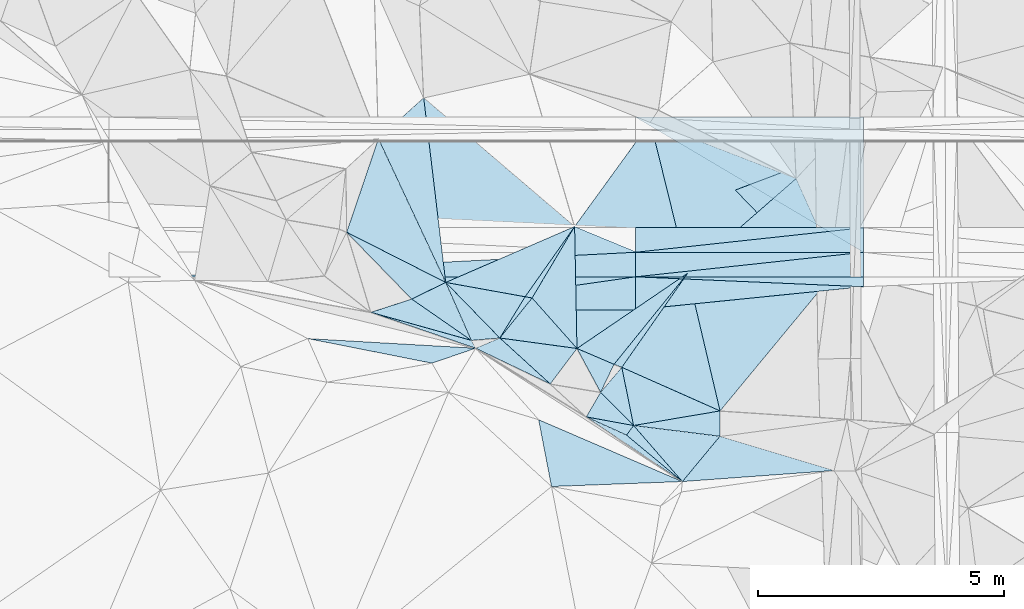
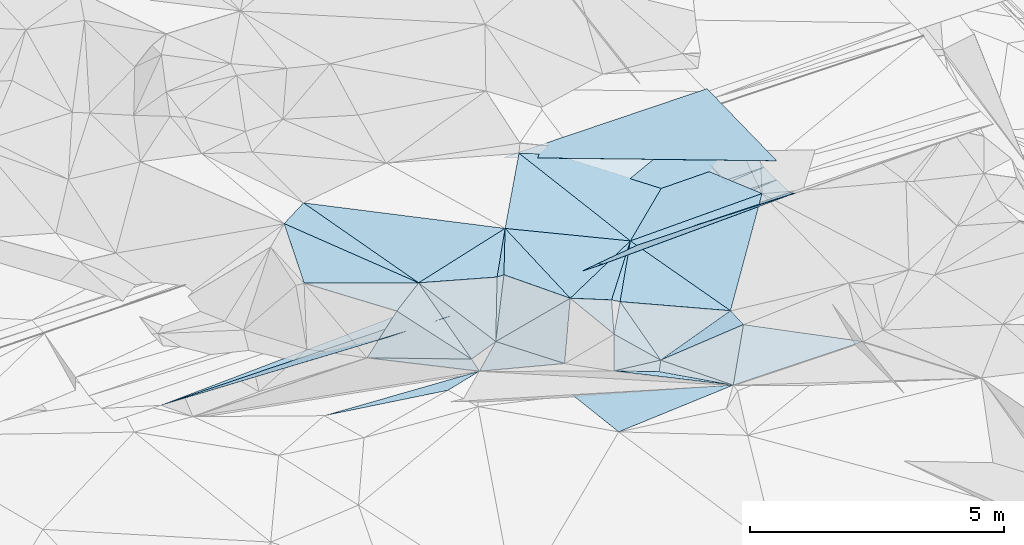
# One storey, part 57 of 275: 47 plates.
"""IFC2X3 building model written with IfcOpenShell, lengths in millimetres."""

from ifc_helpers import new_model, si_unit, frame, origin_with_axes, place, context, subcontext, project, spatial, polyline, outline, extrude, material, type_object, element, save


model = new_model("IFC2X3")

# Units and contexts
model_context = context("Model", 3, precision=1e-05, world=origin_with_axes())
body_context = subcontext(model_context, "Body", "Model", "MODEL_VIEW")
ifc_project = project(units=[si_unit("LENGTHUNIT", "METRE", prefix="MILLI"), si_unit("AREAUNIT", "SQUARE_METRE"), si_unit("VOLUMEUNIT", "CUBIC_METRE"), si_unit("MASSUNIT", "GRAM", prefix="KILO"), si_unit("TIMEUNIT", "SECOND"), si_unit("PLANEANGLEUNIT", "RADIAN"), si_unit("SOLIDANGLEUNIT", "STERADIAN"), si_unit("THERMODYNAMICTEMPERATUREUNIT", "DEGREE_CELSIUS"), si_unit("LUMINOUSINTENSITYUNIT", "LUMEN")], contexts=[model_context])

# Site, building, storey
site_placement = place(None, origin_with_axes())
site = spatial("IfcSite", under=ifc_project, at=site_placement, CompositionType="ELEMENT")
building_placement = place(site_placement, origin_with_axes())
building = spatial("IfcBuilding", under=site, at=building_placement, Name="Undefined", CompositionType="ELEMENT")
storey_placement = place(building_placement, origin_with_axes())
storey = spatial("IfcBuildingStorey", under=building, at=storey_placement, Name="Undefined", CompositionType="ELEMENT", Elevation=0.0)

# Plates
ifc_material = material()
plate_type_1 = type_object("IfcPlateType", PredefinedType="NOTDEFINED")
plate_1_placement = place(storey_placement, frame((-110108.130201798, 60543.2126302947, 49129.6741685446), z_axis=(0.0070360534464846, 0.0249911698384873, -0.999662910876462), x_axis=(0.99997523963564, -5.72709999785377e-05, 0.00703681999743575)))
element("IfcPlate", 1, at=plate_1_placement, inside=storey, type_object=plate_type_1, material=ifc_material, Name="00_PR", context=body_context, shape_type="SweptSolid", body=[
    extrude(outline(polyline([(0.0, 0.0), (4638.88525390625, 2.71393219009042e-09), (4638.4013671875, 2750.85913085938), (0.0, 0.0)])), frame((-8.85201319254618e-08, 2.18876761149539e-07, -0.5000001331573), z_axis=(0.0, 0.0, 1.0), x_axis=(1.0, 0.0, 0.0)), (0.0, 0.0, 1.0), 1.0),
])
plate_type_2 = type_object("IfcPlateType", PredefinedType="NOTDEFINED")
plate_2_placement = place(storey_placement, frame((-111348.333237927, 58316.7714855558, 49209.5070096268), z_axis=(0.118317896493051, -0.117903527485175, -0.985951131434014), x_axis=(-0.511152007933592, -0.858496435201441, 0.0413218529579049)))
element("IfcPlate", 2, at=plate_2_placement, inside=storey, type_object=plate_type_2, material=ifc_material, Name="00", context=body_context, shape_type="SweptSolid", body=[
    extrude(outline(polyline([(0.0, 0.0), (1694.01892089844, -6.30097929388285e-09), (1744.66772460938, 136.508972167969), (0.0, 0.0)])), frame((-8.85201319254618e-08, 2.18876761149539e-07, -0.5000001331573), z_axis=(0.0, 0.0, 1.0), x_axis=(1.0, 0.0, 0.0)), (0.0, 0.0, 1.0), 1.0),
])
plate_type_3 = type_object("IfcPlateType", PredefinedType="NOTDEFINED")
plate_3_placement = place(storey_placement, frame((-111348.462953635, 58316.8629109501, 49209.5060552723), z_axis=(-0.141119786650012, 0.0649496054498312, -0.987859683643262), x_axis=(-0.576000859042115, -0.816949621354208, 0.0285714289450594)))
element("IfcPlate", 3, at=plate_3_placement, inside=storey, type_object=plate_type_3, material=ifc_material, Name="00", context=body_context, shape_type="SweptSolid", body=[
    extrude(outline(polyline([(0.0, 0.0), (1750.0, 6.83940015733242e-10), (2449.71435546875, 1506.28674316406), (0.0, 0.0)])), frame((-8.85201319254618e-08, 2.18876761149539e-07, -0.5000001331573), z_axis=(0.0, 0.0, 1.0), x_axis=(1.0, 0.0, 0.0)), (0.0, 0.0, 1.0), 1.0),
])
plate_type_4 = type_object("IfcPlateType", PredefinedType="NOTDEFINED")
for number, where, z_axis, x_axis, name in (
    (4, (-105469.543799526, 57292.9343954647, 48637.3170069991), (0.00703682011736074, -4.02993598015843e-07, -0.99997524127474), (-0.999975239635043, 5.72709690146696e-05, -0.00703682008264182), "00_PR"),
    (5, (-110108.285337463, 57793.2000715565, 48604.6740063112), (0.00703682011736074, -4.02993598015843e-07, -0.99997524127474), (0.99997523963564, -5.72709999785377e-05, 0.00703681999743575), "00_PR"),
    (6, (-105469.515154169, 57792.9343995453, 48637.3170068708), (0.00703682011736074, -4.02993598015843e-07, -0.99997524127474), (-0.999975239635043, 5.72709690146696e-05, -0.00703682008264182), "00_PR"),
    (7, (-110108.256692113, 58293.2000747863, 48604.6740064954), (0.00703682011736074, -4.02993598015843e-07, -0.99997524127474), (0.99997523963564, -5.72709999785377e-05, 0.00703681999743575), "00_PR"),
):
    element("IfcPlate", number, at=place(storey_placement, frame(where, z_axis=z_axis, x_axis=x_axis)), inside=storey, type_object=plate_type_4, material=ifc_material, Name=name, context=body_context, shape_type="SweptSolid", body=[
        extrude(outline(polyline([(0.0, 0.0), (4638.88525390625, 2.71393219009042e-09), (-1.0997784556821e-05, 500.0), (0.0, 0.0)])), frame((-8.85201319254618e-08, 2.18876761149539e-07, -0.5000001331573), z_axis=(0.0, 0.0, 1.0), x_axis=(1.0, 0.0, 0.0)), (0.0, 0.0, 1.0), 1.0),
    ])
plate_4_placement = place(storey_placement, frame((-110108.284694637, 57793.2000674163, 48604.6740113437), z_axis=(0.00832550512650313, -4.76525014343269e-07, -0.999965342381505), x_axis=(-5.72939716861899e-05, -0.9999999983587, -3.69036567042244e-11)))
element("IfcPlate", 8, at=plate_4_placement, inside=storey, type_object=plate_type_4, material=ifc_material, Name="00_PR", context=body_context, shape_type="SweptSolid", body=[
    extrude(outline(polyline([(0.0, 0.0), (500.0, 8.00355337560177e-10), (499.999267578125, 9668.6904296875), (0.0, 0.0)])), frame((-8.85201319254618e-08, 2.18876761149539e-07, -0.5000001331573), z_axis=(0.0, 0.0, 1.0), x_axis=(1.0, 0.0, 0.0)), (0.0, 0.0, 1.0), 1.0),
])
plate_type_5 = type_object("IfcPlateType", PredefinedType="NOTDEFINED")
plate_5_placement = place(storey_placement, frame((-108387.895050111, 54563.4064522429, 48469.5014773337), z_axis=(0.00794571382185454, 0.0765768338140244, -0.997032022632614), x_axis=(-0.228467255177366, 0.970830094869095, 0.0727436609484561)))
element("IfcPlate", 9, at=plate_5_placement, inside=storey, type_object=plate_type_5, material=ifc_material, Name="00", context=body_context, shape_type="SweptSolid", body=[
    extrude(outline(polyline([(0.0, 0.0), (2886.849609375, 1.07684172689915e-09), (2267.76635742188, 2976.46362304688), (0.0, 0.0)])), frame((-8.85201319254618e-08, 2.18876761149539e-07, -0.5000001331573), z_axis=(0.0, 0.0, 1.0), x_axis=(1.0, 0.0, 0.0)), (0.0, 0.0, 1.0), 1.0),
])
plate_type_6 = type_object("IfcPlateType", PredefinedType="NOTDEFINED")
plate_6_placement = place(storey_placement, frame((-110818.863729709, 54943.0642465037, 48529.5756124602), z_axis=(0.0982026984536422, 0.519601543104053, -0.848746408781981), x_axis=(-0.427884643088709, 0.792055631742686, 0.435387882736236)))
element("IfcPlate", 10, at=plate_6_placement, inside=storey, type_object=plate_type_6, material=ifc_material, Name="00", context=body_context, shape_type="SweptSolid", body=[
    extrude(outline(polyline([(0.0, 0.0), (1125.43322753906, 4.36557456851006e-11), (499.274383544922, 541.871826171875), (0.0, 0.0)])), frame((-8.85201319254618e-08, 2.18876761149539e-07, -0.5000001331573), z_axis=(0.0, 0.0, 1.0), x_axis=(1.0, 0.0, 0.0)), (0.0, 0.0, 1.0), 1.0),
])
plate_type_7 = type_object("IfcPlateType", PredefinedType="NOTDEFINED")
plate_7_placement = place(storey_placement, frame((-110108.351901856, 56622.9222206442, 48939.7537925637), z_axis=(0.00742096432330843, -0.447201487227019, -0.894402459248886), x_axis=(-0.99997175399953, -0.00438480203242347, -0.00610448312635008)))
element("IfcPlate", 11, at=plate_7_placement, inside=storey, type_object=plate_type_7, material=ifc_material, Name="00_PR", context=body_context, shape_type="SweptSolid", body=[
    extrude(outline(polyline([(0.0, 0.0), (4834.31591796875, -1.61999196279794e-08), (-0.930998980998993, 749.142761230469), (0.0, 0.0)])), frame((-8.85201319254618e-08, 2.18876761149539e-07, -0.5000001331573), z_axis=(0.0, 0.0, 1.0), x_axis=(1.0, 0.0, 0.0)), (0.0, 0.0, 1.0), 1.0),
])
plate_type_8 = type_object("IfcPlateType", PredefinedType="NOTDEFINED")
plate_8_placement = place(storey_placement, frame((-105469.555882257, 57091.0572982623, 48738.1967896479), z_axis=(0.00626839832727936, -0.447204963232835, -0.894409541564897), x_axis=(-0.99401798857171, -0.100313664992917, 0.043190357853821)))
element("IfcPlate", 12, at=plate_8_placement, inside=storey, type_object=plate_type_8, material=ifc_material, Name="00_PR", context=body_context, shape_type="SweptSolid", body=[
    extrude(outline(polyline([(0.0, 0.0), (4666.712890625, 6.54836185276508e-10), (4584.98974609375, 744.672485351563), (0.0, 0.0)])), frame((-8.85201319254618e-08, 2.18876761149539e-07, -0.5000001331573), z_axis=(0.0, 0.0, 1.0), x_axis=(1.0, 0.0, 0.0)), (0.0, 0.0, 1.0), 1.0),
])
plate_type_9 = type_object("IfcPlateType", PredefinedType="NOTDEFINED")
plate_9_placement = place(storey_placement, frame((-111111.231218574, 54442.1170434392, 48049.6227013077), z_axis=(0.140310863042225, 0.641044055143108, -0.754569666152852), x_axis=(0.388335524881985, 0.665413130303873, 0.637511479217303)))
element("IfcPlate", 13, at=plate_9_placement, inside=storey, type_object=plate_type_9, material=ifc_material, Name="00", context=body_context, shape_type="SweptSolid", body=[
    extrude(outline(polyline([(0.0, 0.0), (752.927612304688, -3.78349795937538e-09), (276.387786865234, 939.739196777344), (0.0, 0.0)])), frame((-8.85201319254618e-08, 2.18876761149539e-07, -0.5000001331573), z_axis=(0.0, 0.0, 1.0), x_axis=(1.0, 0.0, 0.0)), (0.0, 0.0, 1.0), 1.0),
])
plate_type_10 = type_object("IfcPlateType", PredefinedType="NOTDEFINED")
plate_10_placement = place(storey_placement, frame((-105469.386337756, 60043.0556815237, 49074.8319350457), z_axis=(0.00684061845241066, 0.242529579853101, -0.970119894052002), x_axis=(-5.55829338407661e-05, -0.970142368584362, -0.242536144910531)))
element("IfcPlate", 14, at=plate_10_placement, inside=storey, type_object=plate_type_10, material=ifc_material, Name="00_PR", context=body_context, shape_type="SweptSolid", body=[
    extrude(outline(polyline([(0.0, 0.0), (1803.85876464844, 6.72298483550549e-09), (1811.77587890625, 4638.87841796875), (0.0, 0.0)])), frame((-8.85201319254618e-08, 2.18876761149539e-07, -0.5000001331573), z_axis=(0.0, 0.0, 1.0), x_axis=(1.0, 0.0, 0.0)), (0.0, 0.0, 1.0), 1.0),
])
plate_type_11 = type_object("IfcPlateType", PredefinedType="NOTDEFINED")
plate_11_placement = place(storey_placement, frame((-110108.314367987, 57292.9764647794, 48604.7267894278), z_axis=(0.00626833872603135, -0.447205995914008, -0.894409025641052), x_axis=(0.99997523963564, -5.72709999785377e-05, 0.00703681999743575)))
element("IfcPlate", 15, at=plate_11_placement, inside=storey, type_object=plate_type_11, material=ifc_material, Name="00_PR", context=body_context, shape_type="SweptSolid", body=[
    extrude(outline(polyline([(0.0, 0.0), (4638.88525390625, 2.71393219009042e-09), (4639.59423828125, 225.454452514648), (0.0, 0.0)])), frame((-8.85201319254618e-08, 2.18876761149539e-07, -0.5000001331573), z_axis=(0.0, 0.0, 1.0), x_axis=(1.0, 0.0, 0.0)), (0.0, 0.0, 1.0), 1.0),
])
plate_type_12 = type_object("IfcPlateType", PredefinedType="NOTDEFINED")
plate_12_placement = place(storey_placement, frame((-119776.669424815, 57293.5311547901, 48524.2297912186), z_axis=(0.00742096432330843, -0.447201487227019, -0.894402459248886), x_axis=(0.999965340787191, -5.73519775278889e-05, 0.0083254990906575)))
element("IfcPlate", 16, at=plate_12_placement, inside=storey, type_object=plate_type_12, material=ifc_material, Name="00_PR", context=body_context, shape_type="SweptSolid", body=[
    extrude(outline(polyline([(0.0, 0.0), (9668.6904296875, -3.96539689972997e-09), (4837.22412109375, 773.147644042969), (0.0, 0.0)])), frame((-8.85201319254618e-08, 2.18876761149539e-07, -0.5000001331573), z_axis=(0.0, 0.0, 1.0), x_axis=(1.0, 0.0, 0.0)), (0.0, 0.0, 1.0), 1.0),
])
plate_type_13 = type_object("IfcPlateType", PredefinedType="NOTDEFINED")
plate_13_placement = place(storey_placement, frame((-111300.2894686, 55834.5245966379, 49019.6548490621), z_axis=(0.357932302086088, 0.628815344195722, -0.690272214439614), x_axis=(-0.417551349960722, -0.553428701375684, -0.720671591392087)))
element("IfcPlate", 17, at=plate_13_placement, inside=storey, type_object=plate_type_13, material=ifc_material, Name="00", context=body_context, shape_type="SweptSolid", body=[
    extrude(outline(polyline([(0.0, 0.0), (1304.3388671875, -1.65891833603382e-09), (984.4833984375, 1388.01745605469), (0.0, 0.0)])), frame((-8.85201319254618e-08, 2.18876761149539e-07, -0.5000001331573), z_axis=(0.0, 0.0, 1.0), x_axis=(1.0, 0.0, 0.0)), (0.0, 0.0, 1.0), 1.0),
])
plate_type_14 = type_object("IfcPlateType", PredefinedType="NOTDEFINED")
plate_14_placement = place(storey_placement, frame((-115342.442297878, 60104.5354264326, 49639.5201456464), z_axis=(-0.26848918793394, -0.0830807664708027, -0.959693254225118), x_axis=(0.716681802018761, 0.648461961235842, -0.256640369944613)))
element("IfcPlate", 18, at=plate_14_placement, inside=storey, type_object=plate_type_14, material=ifc_material, Name="00", context=body_context, shape_type="SweptSolid", body=[
    extrude(outline(polyline([(0.0, 0.0), (1285.84606933594, 2.15368345379829e-09), (-882.065185546875, 3110.73315429688), (0.0, 0.0)])), frame((-8.85201319254618e-08, 2.18876761149539e-07, -0.5000001331573), z_axis=(0.0, 0.0, 1.0), x_axis=(1.0, 0.0, 0.0)), (0.0, 0.0, 1.0), 1.0),
])
plate_type_15 = type_object("IfcPlateType", PredefinedType="NOTDEFINED")
plate_15_placement = place(storey_placement, frame((-110148.035891096, 54266.558655415, 48079.5866519528), z_axis=(0.0894039331738282, 0.555522180011531, -0.826681343837083), x_axis=(-0.167035528239186, 0.826612473852879, 0.537411341875737)))
element("IfcPlate", 19, at=plate_15_placement, inside=storey, type_object=plate_type_15, material=ifc_material, Name="00", context=body_context, shape_type="SweptSolid", body=[
    extrude(outline(polyline([(0.0, 0.0), (1432.79443359375, 5.55883161723614e-09), (161.153610229492, 1820.06311035156), (0.0, 0.0)])), frame((-8.85201319254618e-08, 2.18876761149539e-07, -0.5000001331573), z_axis=(0.0, 0.0, 1.0), x_axis=(1.0, 0.0, 0.0)), (0.0, 0.0, 1.0), 1.0),
])
plate_type_16 = type_object("IfcPlateType", PredefinedType="NOTDEFINED")
plate_16_placement = place(storey_placement, frame((-109155.00348539, 53125.4588620502, 47820.5027350372), z_axis=(-0.0575695801158131, 0.0874492234872463, -0.994504085842168), x_axis=(-0.825776688911588, 0.555652118738163, 0.0966622107754904)))
element("IfcPlate", 20, at=plate_16_placement, inside=storey, type_object=plate_type_16, material=ifc_material, Name="00", context=body_context, shape_type="SweptSolid", body=[
    extrude(outline(polyline([(0.0, 0.0), (2369.07470703125, -7.24867277313024e-09), (1478.78198242188, 150.594985961914), (0.0, 0.0)])), frame((-8.85201319254618e-08, 2.18876761149539e-07, -0.5000001331573), z_axis=(0.0, 0.0, 1.0), x_axis=(1.0, 0.0, 0.0)), (0.0, 0.0, 1.0), 1.0),
])
plate_type_17 = type_object("IfcPlateType", PredefinedType="NOTDEFINED")
plate_17_placement = place(storey_placement, frame((-111111.248339455, 54442.0108979438, 48049.551399756), z_axis=(0.106069216308666, 0.428753118129499, -0.897173386278203), x_axis=(0.983339200171674, -0.179181552867264, 0.0306265982082471)))
element("IfcPlate", 21, at=plate_17_placement, inside=storey, type_object=plate_type_17, material=ifc_material, Name="00", context=body_context, shape_type="SweptSolid", body=[
    extrude(outline(polyline([(0.0, 0.0), (979.540710449219, 6.7593646235764e-09), (869.8974609375, 242.029678344727), (0.0, 0.0)])), frame((-8.85201319254618e-08, 2.18876761149539e-07, -0.5000001331573), z_axis=(0.0, 0.0, 1.0), x_axis=(1.0, 0.0, 0.0)), (0.0, 0.0, 1.0), 1.0),
])
plate_type_18 = type_object("IfcPlateType", PredefinedType="NOTDEFINED")
plate_18_placement = place(storey_placement, frame((-110147.985122126, 54266.4670971712, 48079.5458790212), z_axis=(0.190949285751026, 0.372401957258627, -0.908215366805207), x_axis=(0.647154450919668, -0.743441717625469, -0.168776565757677)))
element("IfcPlate", 22, at=plate_18_placement, inside=storey, type_object=plate_type_18, material=ifc_material, Name="00", context=body_context, shape_type="SweptSolid", body=[
    extrude(outline(polyline([(0.0, 0.0), (1534.5732421875, -4.98403096571565e-09), (70.3909072875977, 256.213043212891), (0.0, 0.0)])), frame((-8.85201319254618e-08, 2.18876761149539e-07, -0.5000001331573), z_axis=(0.0, 0.0, 1.0), x_axis=(1.0, 0.0, 0.0)), (0.0, 0.0, 1.0), 1.0),
])
plate_type_19 = type_object("IfcPlateType", PredefinedType="NOTDEFINED")
plate_19_placement = place(storey_placement, frame((-110545.835635063, 55511.9437629666, 48909.528618704), z_axis=(-0.306738252636745, 0.130914932797551, -0.942747540299082), x_axis=(0.62560095574774, 0.774209290031775, -0.0960386349132949)))
element("IfcPlate", 23, at=plate_19_placement, inside=storey, type_object=plate_type_19, material=ifc_material, Name="00", context=body_context, shape_type="SweptSolid", body=[
    extrude(outline(polyline([(0.0, 0.0), (2394.86962890625, -1.04773789644241e-08), (57.3726463317871, 170.611785888672), (0.0, 0.0)])), frame((-8.85201319254618e-08, 2.18876761149539e-07, -0.5000001331573), z_axis=(0.0, 0.0, 1.0), x_axis=(1.0, 0.0, 0.0)), (0.0, 0.0, 1.0), 1.0),
])
plate_type_20 = type_object("IfcPlateType", PredefinedType="NOTDEFINED")
plate_20_placement = place(storey_placement, frame((-113972.31470361, 57179.0555591736, 49509.6535420506), z_axis=(-0.117926896846976, 0.711327610928032, -0.692897017551281), x_axis=(0.284808060230799, -0.644223115966226, -0.709831631925724)))
element("IfcPlate", 24, at=plate_20_placement, inside=storey, type_object=plate_type_20, material=ifc_material, Name="00", context=body_context, shape_type="SweptSolid", body=[
    extrude(outline(polyline([(0.0, 0.0), (1831.42016601563, 5.0495145842433e-09), (184.39241027832, 782.751220703125), (0.0, 0.0)])), frame((-8.85201319254618e-08, 2.18876761149539e-07, -0.5000001331573), z_axis=(0.0, 0.0, 1.0), x_axis=(1.0, 0.0, 0.0)), (0.0, 0.0, 1.0), 1.0),
])
plate_type_21 = type_object("IfcPlateType", PredefinedType="NOTDEFINED")
plate_21_placement = place(storey_placement, frame((-109047.444722096, 57366.0107181013, 48679.500021956), z_axis=(0.00976251929153443, 0.00437358088411713, -0.999942780866652), x_axis=(0.753400420505299, 0.657482416826517, 0.0102312240910843)))
element("IfcPlate", 25, at=plate_21_placement, inside=storey, type_object=plate_type_21, material=ifc_material, Name="00", context=body_context, shape_type="SweptSolid", body=[
    extrude(outline(polyline([(0.0, 0.0), (2932.20043945313, -9.08039510250092e-09), (2339.4375, 1941.55407714844), (0.0, 0.0)])), frame((-8.85201319254618e-08, 2.18876761149539e-07, -0.5000001331573), z_axis=(0.0, 0.0, 1.0), x_axis=(1.0, 0.0, 0.0)), (0.0, 0.0, 1.0), 1.0),
])
plate_type_22 = type_object("IfcPlateType", PredefinedType="NOTDEFINED")
plate_22_placement = place(storey_placement, frame((-108387.793925697, 54563.386729321, 48469.5115157811), z_axis=(0.210195101245394, 0.0371290986917973, -0.976954169571313), x_axis=(-0.00393270977097862, -0.999238397367837, -0.0388221459944492)))
element("IfcPlate", 26, at=plate_22_placement, inside=storey, type_object=plate_type_22, material=ifc_material, Name="00", context=body_context, shape_type="SweptSolid", body=[
    extrude(outline(polyline([(0.0, 0.0), (515.169860839844, -2.03726813197136e-10), (318.923919677734, 1799.13525390625), (0.0, 0.0)])), frame((-8.85201319254618e-08, 2.18876761149539e-07, -0.5000001331573), z_axis=(0.0, 0.0, 1.0), x_axis=(1.0, 0.0, 0.0)), (0.0, 0.0, 1.0), 1.0),
])
plate_type_23 = type_object("IfcPlateType", PredefinedType="NOTDEFINED")
plate_23_placement = place(storey_placement, frame((-111844.926758326, 55112.6597465711, 48079.6448897377), z_axis=(0.340303572425614, 0.616295743811134, -0.710192251967484), x_axis=(-0.900310439937184, 0.431506897793999, -0.0569465441999276)))
element("IfcPlate", 27, at=plate_23_placement, inside=storey, type_object=plate_type_23, material=ifc_material, Name="00", context=body_context, shape_type="SweptSolid", body=[
    extrude(outline(polyline([(0.0, 0.0), (1685.79150390625, 8.41464498080313e-09), (1308.732421875, 562.244995117188), (0.0, 0.0)])), frame((-8.85201319254618e-08, 2.18876761149539e-07, -0.5000001331573), z_axis=(0.0, 0.0, 1.0), x_axis=(1.0, 0.0, 0.0)), (0.0, 0.0, 1.0), 1.0),
])
plate_type_24 = type_object("IfcPlateType", PredefinedType="NOTDEFINED")
plate_24_placement = place(storey_placement, frame((-112870.721491134, 56047.8506862479, 48399.6835438836), z_axis=(0.143589438162017, 0.760816439699102, -0.632882626031004), x_axis=(-0.947285132532127, -0.0794174781395136, -0.31039288305235)))
element("IfcPlate", 28, at=plate_24_placement, inside=storey, type_object=plate_type_24, material=ifc_material, Name="00", context=body_context, shape_type="SweptSolid", body=[
    extrude(outline(polyline([(0.0, 0.0), (612.12744140625, 1.83354131877422e-09), (609.023498535156, 1831.41760253906), (0.0, 0.0)])), frame((-8.85201319254618e-08, 2.18876761149539e-07, -0.5000001331573), z_axis=(0.0, 0.0, 1.0), x_axis=(1.0, 0.0, 0.0)), (0.0, 0.0, 1.0), 1.0),
])
plate_type_25 = type_object("IfcPlateType", PredefinedType="NOTDEFINED")
plate_25_placement = place(storey_placement, frame((-109047.537646219, 57366.0678281826, 48679.5113905339), z_axis=(-0.176079743766333, 0.118601823670062, -0.977204958674135), x_axis=(-0.903944518769192, 0.373538295662999, 0.208214909793503)))
element("IfcPlate", 29, at=plate_25_placement, inside=storey, type_object=plate_type_25, material=ifc_material, Name="00", context=body_context, shape_type="SweptSolid", body=[
    extrude(outline(polyline([(0.0, 0.0), (2545.44702148438, 1.50375853991136e-08), (1940.83801269531, 2555.41552734375), (0.0, 0.0)])), frame((-8.85201319254618e-08, 2.18876761149539e-07, -0.5000001331573), z_axis=(0.0, 0.0, 1.0), x_axis=(1.0, 0.0, 0.0)), (0.0, 0.0, 1.0), 1.0),
])
plate_type_26 = type_object("IfcPlateType", PredefinedType="NOTDEFINED")
plate_26_placement = place(storey_placement, frame((-113972.246211693, 57179.0547205819, 49509.6478352102), z_axis=(0.0190669061535407, 0.709647029122215, -0.704299330645534), x_axis=(0.972898944223689, -0.175528923877829, -0.150523224821697)))
element("IfcPlate", 30, at=plate_26_placement, inside=storey, type_object=plate_type_26, material=ifc_material, Name="00", context=body_context, shape_type="SweptSolid", body=[
    extrude(outline(polyline([(0.0, 0.0), (1660.87329101563, -2.29920260608196e-09), (1437.25598144531, 1288.13635253906), (0.0, 0.0)])), frame((-8.85201319254618e-08, 2.18876761149539e-07, -0.5000001331573), z_axis=(0.0, 0.0, 1.0), x_axis=(1.0, 0.0, 0.0)), (0.0, 0.0, 1.0), 1.0),
])
plate_type_27 = type_object("IfcPlateType", PredefinedType="NOTDEFINED")
plate_27_placement = place(storey_placement, frame((-110387.416169875, 55450.9180428106, 48849.5801073038), z_axis=(-0.0159846802229624, 0.542727036094709, -0.839757020982869), x_axis=(0.167035528209662, -0.826612473889015, -0.537411341829331)))
element("IfcPlate", 31, at=plate_27_placement, inside=storey, type_object=plate_type_27, material=ifc_material, Name="00", context=body_context, shape_type="SweptSolid", body=[
    extrude(outline(polyline([(0.0, 0.0), (1432.79443359375, 5.55883161723614e-09), (519.683776855469, 525.764953613281), (0.0, 0.0)])), frame((-8.85201319254618e-08, 2.18876761149539e-07, -0.5000001331573), z_axis=(0.0, 0.0, 1.0), x_axis=(1.0, 0.0, 0.0)), (0.0, 0.0, 1.0), 1.0),
])
plate_type_28 = type_object("IfcPlateType", PredefinedType="NOTDEFINED")
plate_28_placement = place(storey_placement, frame((-110387.494356405, 55450.6632795703, 48849.507755593), z_axis=(-0.172361861841253, 0.0332037448347834, -0.984473920381624), x_axis=(0.571724193775576, 0.81723326205722, -0.0725344169272878)))
element("IfcPlate", 32, at=plate_28_placement, inside=storey, type_object=plate_type_28, material=ifc_material, Name="00", context=body_context, shape_type="SweptSolid", body=[
    extrude(outline(polyline([(0.0, 0.0), (2343.71508789063, 1.77533365786076e-09), (445.617309570313, 2175.11499023438), (0.0, 0.0)])), frame((-8.85201319254618e-08, 2.18876761149539e-07, -0.5000001331573), z_axis=(0.0, 0.0, 1.0), x_axis=(1.0, 0.0, 0.0)), (0.0, 0.0, 1.0), 1.0),
])
plate_type_29 = type_object("IfcPlateType", PredefinedType="NOTDEFINED")
plate_29_placement = place(storey_placement, frame((-111300.541504038, 55834.2078767654, 49019.5053659649), z_axis=(-0.146144219194308, -0.00462213095117887, -0.989252497141936), x_axis=(0.82060446065063, 0.557918354017747, -0.123836300858902)))
element("IfcPlate", 33, at=plate_29_placement, inside=storey, type_object=plate_type_29, material=ifc_material, Name="00", context=body_context, shape_type="SweptSolid", body=[
    extrude(outline(polyline([(0.0, 0.0), (2745.56005859375, 5.34055288881063e-09), (453.168029785156, 693.064758300781), (0.0, 0.0)])), frame((-8.85201319254618e-08, 2.18876761149539e-07, -0.5000001331573), z_axis=(0.0, 0.0, 1.0), x_axis=(1.0, 0.0, 0.0)), (0.0, 0.0, 1.0), 1.0),
])
plate_type_30 = type_object("IfcPlateType", PredefinedType="NOTDEFINED")
plate_30_placement = place(storey_placement, frame((-113450.583981408, 55999.280835229, 48209.7442957893), z_axis=(0.137039774955496, 0.84835168522305, -0.511389790922109), x_axis=(-0.946479625237211, 0.264443711857154, 0.185056321886175)))
element("IfcPlate", 34, at=plate_30_placement, inside=storey, type_object=plate_type_30, material=ifc_material, Name="00", context=body_context, shape_type="SweptSolid", body=[
    extrude(outline(polyline([(0.0, 0.0), (2161.50415039063, -1.10958353616297e-08), (1569.18505859375, 929.009216308594), (0.0, 0.0)])), frame((-8.85201319254618e-08, 2.18876761149539e-07, -0.5000001331573), z_axis=(0.0, 0.0, 1.0), x_axis=(1.0, 0.0, 0.0)), (0.0, 0.0, 1.0), 1.0),
])
plate_type_31 = type_object("IfcPlateType", PredefinedType="NOTDEFINED")
plate_31_placement = place(storey_placement, frame((-112870.606641536, 56047.7328243543, 48399.6175843818), z_axis=(0.373276946388769, 0.525095279300726, -0.764813224879623), x_axis=(0.480118664490163, 0.596072121761362, 0.64357135864416)))
element("IfcPlate", 35, at=plate_31_placement, inside=storey, type_object=plate_type_31, material=ifc_material, Name="00", context=body_context, shape_type="SweptSolid", body=[
    extrude(outline(polyline([(0.0, 0.0), (1367.36975097656, -3.59432306140661e-09), (1025.83813476563, 1357.73937988281), (0.0, 0.0)])), frame((-8.85201319254618e-08, 2.18876761149539e-07, -0.5000001331573), z_axis=(0.0, 0.0, 1.0), x_axis=(1.0, 0.0, 0.0)), (0.0, 0.0, 1.0), 1.0),
])
plate_type_32 = type_object("IfcPlateType", PredefinedType="NOTDEFINED")
plate_32_placement = place(storey_placement, frame((-108389.807004153, 54048.793607579, 48449.5585451523), z_axis=(0.236063338380791, 0.405924279527758, -0.882892733893754), x_axis=(-0.565047936856909, -0.681836023210694, -0.464564814106683)))
element("IfcPlate", 36, at=plate_32_placement, inside=storey, type_object=plate_type_32, material=ifc_material, Name="00", context=body_context, shape_type="SweptSolid", body=[
    extrude(outline(polyline([(0.0, 0.0), (1353.95532226563, -6.00994098931551e-09), (1016.90209960938, 1497.1005859375), (0.0, 0.0)])), frame((-8.85201319254618e-08, 2.18876761149539e-07, -0.5000001331573), z_axis=(0.0, 0.0, 1.0), x_axis=(1.0, 0.0, 0.0)), (0.0, 0.0, 1.0), 1.0),
])
plate_type_33 = type_object("IfcPlateType", PredefinedType="NOTDEFINED")
plate_33_placement = place(storey_placement, frame((-113362.768635637, 55840.1991304416, 47983.7314235439), z_axis=(0.127923610807328, 0.833739769312944, -0.537134570535182), x_axis=(-0.911597596902369, 0.312179040754406, 0.267458534796488)))
element("IfcPlate", 37, at=plate_33_placement, inside=storey, type_object=plate_type_33, material=ifc_material, Name="00", context=body_context, shape_type="SweptSolid", body=[
    extrude(outline(polyline([(0.0, 0.0), (2340.5498046875, -7.76708475314081e-09), (190.161743164063, 218.932662963867), (0.0, 0.0)])), frame((-8.85201319254618e-08, 2.18876761149539e-07, -0.5000001331573), z_axis=(0.0, 0.0, 1.0), x_axis=(1.0, 0.0, 0.0)), (0.0, 0.0, 1.0), 1.0),
])
plate_type_34 = type_object("IfcPlateType", PredefinedType="NOTDEFINED")
plate_34_placement = place(storey_placement, frame((-113972.186330433, 57178.8730344973, 49509.5360889999), z_axis=(0.138822271332222, 0.346279344819476, -0.927803315543525), x_axis=(-0.860653253450121, -0.421279087973353, -0.28600683097098)))
element("IfcPlate", 38, at=plate_34_placement, inside=storey, type_object=plate_type_34, material=ifc_material, Name="00", context=body_context, shape_type="SweptSolid", body=[
    extrude(outline(polyline([(0.0, 0.0), (804.176574707031, 3.39059624820948e-09), (1281.06188964844, 1863.51293945313), (0.0, 0.0)])), frame((-8.85201319254618e-08, 2.18876761149539e-07, -0.5000001331573), z_axis=(0.0, 0.0, 1.0), x_axis=(1.0, 0.0, 0.0)), (0.0, 0.0, 1.0), 1.0),
])
plate_type_35 = type_object("IfcPlateType", PredefinedType="NOTDEFINED")
plate_35_placement = place(storey_placement, frame((-112356.286690921, 56887.4844306343, 49259.6274839933), z_axis=(0.2144177115884, 0.631661977305388, -0.745002141865271), x_axis=(0.975949188844834, -0.169278634802373, 0.137360564182576)))
element("IfcPlate", 39, at=plate_35_placement, inside=storey, type_object=plate_type_35, material=ifc_material, Name="00", context=body_context, shape_type="SweptSolid", body=[
    extrude(outline(polyline([(0.0, 0.0), (145.602203369141, 5.23868948221207e-10), (-478.014770507813, 1216.88208007813), (0.0, 0.0)])), frame((-8.85201319254618e-08, 2.18876761149539e-07, -0.5000001331573), z_axis=(0.0, 0.0, 1.0), x_axis=(1.0, 0.0, 0.0)), (0.0, 0.0, 1.0), 1.0),
])
plate_type_36 = type_object("IfcPlateType", PredefinedType="NOTDEFINED")
plate_36_placement = place(storey_placement, frame((-115342.319299754, 60104.5939048695, 49639.5003978087), z_axis=(-0.0224804055502482, 0.033867867457285, -0.999173457874153), x_axis=(0.423722341373349, -0.904899375400655, -0.040205693882716)))
element("IfcPlate", 40, at=plate_36_placement, inside=storey, type_object=plate_type_36, material=ifc_material, Name="00", context=body_context, shape_type="SweptSolid", body=[
    extrude(outline(polyline([(0.0, 0.0), (3233.37280273438, 1.12049747258425e-09), (1451.02355957031, 1391.77258300781), (0.0, 0.0)])), frame((-8.85201319254618e-08, 2.18876761149539e-07, -0.5000001331573), z_axis=(0.0, 0.0, 1.0), x_axis=(1.0, 0.0, 0.0)), (0.0, 0.0, 1.0), 1.0),
])
plate_type_37 = type_object("IfcPlateType", PredefinedType="NOTDEFINED")
plate_37_placement = place(storey_placement, frame((-111300.567563356, 55834.2456835221, 49019.5111971788), z_axis=(-0.198255902303955, 0.0709888134307596, -0.977576178908497), x_axis=(-0.652715576089416, 0.734489169821306, 0.185709547803746)))
element("IfcPlate", 41, at=plate_37_placement, inside=storey, type_object=plate_type_37, material=ifc_material, Name="00", context=body_context, shape_type="SweptSolid", body=[
    extrude(outline(polyline([(0.0, 0.0), (1400.03576660156, 4.65661287307739e-09), (1890.02319335938, 1621.60791015625), (0.0, 0.0)])), frame((-8.85201319254618e-08, 2.18876761149539e-07, -0.5000001331573), z_axis=(0.0, 0.0, 1.0), x_axis=(1.0, 0.0, 0.0)), (0.0, 0.0, 1.0), 1.0),
])
plate_type_38 = type_object("IfcPlateType", PredefinedType="NOTDEFINED")
plate_38_placement = place(storey_placement, frame((-111348.435530633, 58316.7988451913, 49209.5028519275), z_axis=(-0.0862734388611043, -0.0631826290784059, -0.994265985101482), x_axis=(-0.912406684768163, -0.395766766061901, 0.104320220816839)))
element("IfcPlate", 42, at=plate_38_placement, inside=storey, type_object=plate_type_38, material=ifc_material, Name="00", context=body_context, shape_type="SweptSolid", body=[
    extrude(outline(polyline([(0.0, 0.0), (2875.7607421875, 2.73576006293297e-09), (1776.15612792969, 3628.68701171875), (0.0, 0.0)])), frame((-8.85201319254618e-08, 2.18876761149539e-07, -0.5000001331573), z_axis=(0.0, 0.0, 1.0), x_axis=(1.0, 0.0, 0.0)), (0.0, 0.0, 1.0), 1.0),
])
plate_type_39 = type_object("IfcPlateType", PredefinedType="NOTDEFINED")
plate_39_placement = place(storey_placement, frame((-106064.060015542, 53350.7445699145, 47651.6059707135), z_axis=(-0.0874504217522529, 0.609392019025081, -0.788031592567131), x_axis=(-0.995880890775363, -0.0725010841525561, 0.0544503827826243)))
element("IfcPlate", 43, at=plate_39_placement, inside=storey, type_object=plate_type_39, material=ifc_material, Name="00", context=body_context, shape_type="SweptSolid", body=[
    extrude(outline(polyline([(0.0, 0.0), (3103.7431640625, -1.01717887446284e-08), (2309.16284179688, 1096.28332519531), (0.0, 0.0)])), frame((-8.85201319254618e-08, 2.18876761149539e-07, -0.5000001331573), z_axis=(0.0, 0.0, 1.0), x_axis=(1.0, 0.0, 0.0)), (0.0, 0.0, 1.0), 1.0),
])
plate_type_40 = type_object("IfcPlateType", PredefinedType="NOTDEFINED")
plate_40_placement = place(storey_placement, frame((-111348.490350541, 58316.8659705205, 49209.5109631934), z_axis=(-0.19591438165577, 0.0710696840186111, -0.978042256282382), x_axis=(0.903944518761728, -0.373538295724245, -0.208214909716031)))
element("IfcPlate", 44, at=plate_40_placement, inside=storey, type_object=plate_type_40, material=ifc_material, Name="00", context=body_context, shape_type="SweptSolid", body=[
    extrude(outline(polyline([(0.0, 0.0), (2545.44702148438, 1.50375853991136e-08), (1010.23516845703, 2276.23046875), (0.0, 0.0)])), frame((-8.85201319254618e-08, 2.18876761149539e-07, -0.5000001331573), z_axis=(0.0, 0.0, 1.0), x_axis=(1.0, 0.0, 0.0)), (0.0, 0.0, 1.0), 1.0),
])
plate_type_41 = type_object("IfcPlateType", PredefinedType="NOTDEFINED")
plate_41_placement = place(storey_placement, frame((-106838.381612119, 59293.9473726342, 48709.5075629633), z_axis=(-0.106258724769508, 0.137085828190248, -0.984843418579701), x_axis=(-0.75340042052119, -0.657482416808414, -0.0102312240841758)))
element("IfcPlate", 45, at=plate_41_placement, inside=storey, type_object=plate_type_41, material=ifc_material, Name="00", context=body_context, shape_type="SweptSolid", body=[
    extrude(outline(polyline([(0.0, 0.0), (2932.20043945313, -9.08039510250092e-09), (1476.05871582031, 2859.484375), (0.0, 0.0)])), frame((-8.85201319254618e-08, 2.18876761149539e-07, -0.5000001331573), z_axis=(0.0, 0.0, 1.0), x_axis=(1.0, 0.0, 0.0)), (0.0, 0.0, 1.0), 1.0),
])
plate_type_42 = type_object("IfcPlateType", PredefinedType="NOTDEFINED")
plate_42_placement = place(storey_placement, frame((-111818.712960743, 53024.803100595, 47689.5039576826), z_axis=(0.0443285313867585, 0.117959863737391, -0.992028453146455), x_axis=(-0.188292635586043, 0.976193893490183, 0.107663204933434)))
element("IfcPlate", 46, at=plate_42_placement, inside=storey, type_object=plate_type_42, material=ifc_material, Name="00", context=body_context, shape_type="SweptSolid", body=[
    extrude(outline(polyline([(0.0, 0.0), (1393.23364257813, 6.43194653093815e-09), (-389.188140869141, 2640.34985351563), (0.0, 0.0)])), frame((-8.85201319254618e-08, 2.18876761149539e-07, -0.5000001331573), z_axis=(0.0, 0.0, 1.0), x_axis=(1.0, 0.0, 0.0)), (0.0, 0.0, 1.0), 1.0),
])
plate_type_43 = type_object("IfcPlateType", PredefinedType="NOTDEFINED")
plate_43_placement = place(storey_placement, frame((-116779.910054683, 56035.8052344048, 47989.5023152417), z_axis=(-0.00728212530856342, -0.0964532120106071, -0.995310880350369), x_axis=(0.998356296330242, -0.0572855353684806, -0.00175300179961732)))
element("IfcPlate", 47, at=plate_43_placement, inside=storey, type_object=plate_type_43, material=ifc_material, Name="00", context=body_context, shape_type="SweptSolid", body=[
    extrude(outline(polyline([(0.0, 0.0), (3422.69970703125, -1.92158040590584e-08), (2552.71020507813, 356.470397949219), (0.0, 0.0)])), frame((-8.85201319254618e-08, 2.18876761149539e-07, -0.5000001331573), z_axis=(0.0, 0.0, 1.0), x_axis=(1.0, 0.0, 0.0)), (0.0, 0.0, 1.0), 1.0),
])

save(model, "model.ifc")
